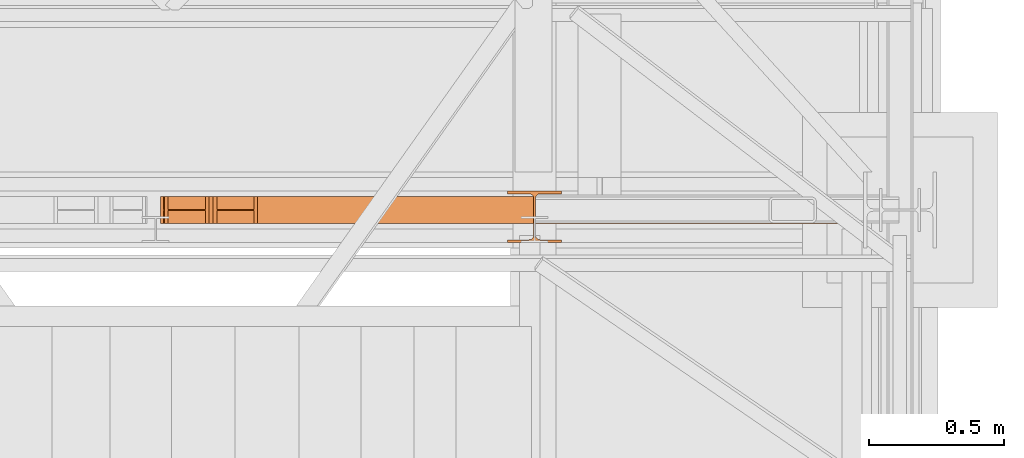
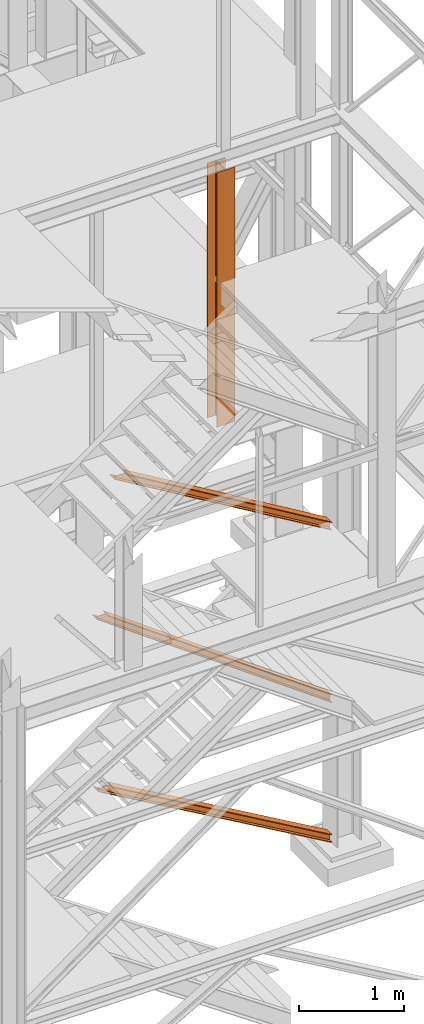
# One storey, part 56 of 208: 4 proxies.
"""IFC2X3 building model written with IfcOpenShell, lengths in millimetres."""

from ifc_helpers import new_model, entity, si_unit, converted_unit, frame, origin, origin_with_axes, place, context, subcontext, project, spatial, faceted_brep, element, save


model = new_model("IFC2X3")

# Units and contexts
model_context = context("Model", 3, precision=1e-05, world=origin())
plan_context = context("Plan", 3, precision=1e-05, world=origin())
body_context = subcontext(model_context, "Body", "Model", "MODEL_VIEW")
ifc_project = project(units=[si_unit("LENGTHUNIT", "METRE", prefix="MILLI"), converted_unit("PLANEANGLEUNIT", "DEGREE", entity("IfcPlaneAngleMeasure", 0.0174532925199433), si_unit("PLANEANGLEUNIT", "RADIAN"), dimensions=[0, 0, 0, 0, 0, 0, 0]), si_unit("AREAUNIT", "SQUARE_METRE"), si_unit("VOLUMEUNIT", "CUBIC_METRE")], contexts=[model_context, plan_context])

# Building, storey
building_placement = place(None, origin())
building = spatial("IfcBuilding", under=ifc_project, at=building_placement, CompositionType="COMPLEX")
storey_placement = place(building_placement, origin_with_axes())
storey = spatial("IfcBuildingStorey", under=building, at=storey_placement, Name="Geschoss", CompositionType="ELEMENT")

# Proxies
proxy_1_placement = place(storey_placement, frame((3966.37953388816, -22112.57439031789, 1566.490000221248), z_axis=(0.0, 0.0, 1.0), x_axis=(1.0, 0.0, 0.0)))
element("IfcBuildingElementProxy", 1, at=proxy_1_placement, inside=storey, context=body_context, shape_type="Brep", body=[
    faceted_brep([(2596.885429276088, 0.00999999999839929, 88.00999999999999), (2596.885429276088, 0.00999999999839929, 96.00999999999999), (2596.885429276088, 100.0099999999984, 96.00999999999999), (2596.885429276088, 100.0099999999984, 88.00999999999999), (2596.885429276088, 52.5099999999984, 88.00999999999999), (2596.885429276088, 52.5099999999984, 8.009999999999991), (2596.885429276088, 100.0099999999984, 8.009999999999991), (2596.885429276088, 100.0099999999984, 0.009999999999990905), (2596.885429276088, 0.00999999999839929, 0.009999999999990905), (2596.885429276088, 0.00999999999839929, 8.009999999999991), (2596.885429276088, 47.5099999999984, 8.009999999999991), (2596.885429276088, 47.5099999999984, 88.00999999999999), (2596.885429276088, 0.00999999999839929, 96.00999999999999), (2596.885429276088, 0.00999999999839929, 88.00999999999999), (121.5012482379625, 0.01000000000567525, 1881.009998688699), (132.5459071686873, 0.01000000000567525, 1881.009998688699), (2596.885429276088, 100.0099999999984, 96.00999999999999), (2596.885429276088, 0.00999999999839929, 96.00999999999999), (132.5459071686873, 0.01000000000567525, 1881.009998688699), (132.5459071686864, 100.0100000000057, 1881.009998688699), (2596.885429276088, 100.0099999999984, 88.00999999999999), (2596.885429276088, 100.0099999999984, 96.00999999999999), (132.5459071686864, 100.0100000000057, 1881.009998688699), (121.5012482379625, 100.010000000002, 1881.009998688699), (2596.885429276088, 52.5099999999984, 88.00999999999999), (2596.885429276088, 100.0099999999984, 88.00999999999999), (121.5012482379625, 100.010000000002, 1881.009998688699), (121.5012482379625, 52.51000000000568, 1881.009998688699), (2596.885429276088, 52.5099999999984, 8.009999999999991), (2596.885429276088, 52.5099999999984, 88.00999999999999), (121.5012482379625, 52.51000000000568, 1881.009998688699), (11.05465893072415, 52.51000000000568, 1881.009998688699), (2596.885429276088, 100.0099999999984, 8.009999999999991), (2596.885429276088, 52.5099999999984, 8.009999999999991), (11.05465893072415, 52.51000000000568, 1881.009998688699), (11.05465893072415, 100.0100000000057, 1881.009998688699), (2596.885429276088, 100.0099999999984, 0.009999999999990905), (2596.885429276088, 100.0099999999984, 8.009999999999991), (11.05465893072415, 100.0100000000057, 1881.009998688699), (0.01000000000021828, 100.0100000000057, 1881.009998688699), (2596.885429276088, 0.00999999999839929, 0.009999999999990905), (2596.885429276088, 100.0099999999984, 0.009999999999990905), (0.01000000000021828, 100.0100000000057, 1881.009998688699), (0.01000000000021828, 0.01000000000567525, 1881.009998688699), (2596.885429276088, 0.00999999999839929, 8.009999999999991), (2596.885429276088, 0.00999999999839929, 0.009999999999990905), (0.01000000000021828, 0.01000000000567525, 1881.009998688699), (11.05465893072415, 0.01000000000203727, 1881.009998688699), (2596.885429276088, 47.5099999999984, 8.009999999999991), (2596.885429276088, 0.00999999999839929, 8.009999999999991), (11.05465893072415, 0.01000000000203727, 1881.009998688699), (11.05465893072324, 47.51000000000568, 1881.0099986887), (2596.885429276088, 47.5099999999984, 88.00999999999999), (2596.885429276088, 47.5099999999984, 8.009999999999991), (11.05465893072324, 47.51000000000568, 1881.0099986887), (121.5012482379625, 47.51000000000568, 1881.009998688699), (2596.885429276088, 0.00999999999839929, 88.00999999999999), (2596.885429276088, 47.5099999999984, 88.00999999999999), (121.5012482379625, 47.51000000000568, 1881.009998688699), (121.5012482379625, 0.01000000000567525, 1881.009998688699), (121.5012482379625, 0.01000000000567525, 1881.009998688699), (121.5012482379625, 47.51000000000568, 1881.009998688699), (11.05465893072324, 47.51000000000568, 1881.0099986887), (11.05465893072415, 0.01000000000203727, 1881.009998688699), (0.01000000000021828, 0.01000000000567525, 1881.009998688699), (0.01000000000021828, 100.0100000000057, 1881.009998688699), (11.05465893072415, 100.0100000000057, 1881.009998688699), (11.05465893072415, 52.51000000000568, 1881.009998688699), (121.5012482379625, 52.51000000000568, 1881.009998688699), (121.5012482379625, 100.010000000002, 1881.009998688699), (132.5459071686864, 100.0100000000057, 1881.009998688699), (132.5459071686873, 0.01000000000567525, 1881.009998688699)], [[[0, 1, 2, 3, 4, 5, 6, 7, 8, 9, 10, 11]], [[12, 13, 14, 15]], [[16, 17, 18, 19]], [[20, 21, 22, 23]], [[24, 25, 26, 27]], [[28, 29, 30, 31]], [[32, 33, 34, 35]], [[36, 37, 38, 39]], [[40, 41, 42, 43]], [[44, 45, 46, 47]], [[48, 49, 50, 51]], [[52, 53, 54, 55]], [[56, 57, 58, 59]], [[60, 61, 62, 63, 64, 65, 66, 67, 68, 69, 70, 71]]], orient=[[False], [False], [False], [False], [False], [False], [False], [False], [False], [False], [False], [False], [False], [False]]),
])
proxy_2_placement = place(storey_placement, frame((3980.145216676689, -22112.57439031789, -65.01000000000045), z_axis=(0.0, 0.0, 1.0), x_axis=(1.0, 0.0, 0.0)))
element("IfcBuildingElementProxy", 2, at=proxy_2_placement, inside=storey, context=body_context, shape_type="Brep", body=[
    faceted_brep([(2583.11974648756, 0.00999999999839929, 88.01000000000005), (2583.11974648756, 0.00999999999839929, 96.01000000000005), (2583.11974648756, 100.0099999999984, 96.01000000000005), (2583.11974648756, 100.0099999999984, 88.01000000000005), (2583.11974648756, 52.5099999999984, 88.01000000000005), (2583.11974648756, 52.5099999999984, 8.010000000000048), (2583.11974648756, 100.0099999999984, 8.010000000000048), (2583.11974648756, 100.0099999999984, 0.01000000000004775), (2583.11974648756, 0.00999999999839929, 0.01000000000004775), (2583.11974648756, 0.00999999999839929, 8.010000000000048), (2583.11974648756, 47.5099999999984, 8.010000000000048), (2583.11974648756, 47.5099999999984, 88.01000000000005), (2583.11974648756, 0.00999999999839929, 96.01000000000005), (2583.11974648756, 0.00999999999839929, 88.01000000000005), (151.704132703544, 0.01000000000567525, 1498.509998909946), (165.4945084038664, 0.01000000000567525, 1498.509998909946), (2583.11974648756, 100.0099999999984, 96.01000000000005), (2583.11974648756, 0.00999999999839929, 96.01000000000005), (165.4945084038664, 0.01000000000567525, 1498.509998909946), (165.4945084038664, 100.010000000002, 1498.509998909947), (2583.11974648756, 100.0099999999984, 88.01000000000005), (2583.11974648756, 100.0099999999984, 96.01000000000005), (165.4945084038664, 100.010000000002, 1498.509998909947), (151.704132703544, 100.0100000000057, 1498.509998909946), (2583.11974648756, 52.5099999999984, 88.01000000000005), (2583.11974648756, 100.0099999999984, 88.01000000000005), (151.704132703544, 100.0100000000057, 1498.509998909946), (151.704132703544, 52.51000000000204, 1498.509998909946), (2583.11974648756, 52.5099999999984, 8.010000000000048), (2583.11974648756, 52.5099999999984, 88.01000000000005), (151.704132703544, 52.51000000000204, 1498.509998909946), (13.80037570032346, 52.51000000000568, 1498.509998909946), (2583.11974648756, 100.0099999999984, 8.010000000000048), (2583.11974648756, 52.5099999999984, 8.010000000000048), (13.80037570032346, 52.51000000000568, 1498.509998909946), (13.80037570032346, 100.0100000000057, 1498.509998909946), (2583.11974648756, 100.0099999999984, 0.01000000000004775), (2583.11974648756, 100.0099999999984, 8.010000000000048), (13.80037570032346, 100.0100000000057, 1498.509998909946), (0.01000000000112777, 100.0100000000057, 1498.509998909946), (2583.11974648756, 0.00999999999839929, 0.01000000000004775), (2583.11974648756, 100.0099999999984, 0.01000000000004775), (0.01000000000112777, 100.0100000000057, 1498.509998909946), (0.01000000000021828, 0.01000000000567525, 1498.509998909947), (2583.11974648756, 0.00999999999839929, 8.010000000000048), (2583.11974648756, 0.00999999999839929, 0.01000000000004775), (0.01000000000021828, 0.01000000000567525, 1498.509998909947), (13.80037570032346, 0.01000000000567525, 1498.509998909946), (2583.11974648756, 47.5099999999984, 8.010000000000048), (2583.11974648756, 0.00999999999839929, 8.010000000000048), (13.80037570032346, 0.01000000000567525, 1498.509998909946), (13.80037570032346, 47.51000000000568, 1498.509998909946), (2583.11974648756, 47.5099999999984, 88.01000000000005), (2583.11974648756, 47.5099999999984, 8.010000000000048), (13.80037570032346, 47.51000000000568, 1498.509998909946), (151.704132703544, 47.51000000000568, 1498.509998909946), (2583.11974648756, 0.00999999999839929, 88.01000000000005), (2583.11974648756, 47.5099999999984, 88.01000000000005), (151.704132703544, 47.51000000000568, 1498.509998909946), (151.704132703544, 0.01000000000567525, 1498.509998909946), (151.704132703544, 0.01000000000567525, 1498.509998909946), (151.704132703544, 47.51000000000568, 1498.509998909946), (13.80037570032346, 47.51000000000568, 1498.509998909946), (13.80037570032346, 0.01000000000567525, 1498.509998909946), (0.01000000000021828, 0.01000000000567525, 1498.509998909947), (0.01000000000112777, 100.0100000000057, 1498.509998909946), (13.80037570032346, 100.0100000000057, 1498.509998909946), (13.80037570032346, 52.51000000000568, 1498.509998909946), (151.704132703544, 52.51000000000204, 1498.509998909946), (151.704132703544, 100.0100000000057, 1498.509998909946), (165.4945084038664, 100.010000000002, 1498.509998909947), (165.4945084038664, 0.01000000000567525, 1498.509998909946)], [[[0, 1, 2, 3, 4, 5, 6, 7, 8, 9, 10, 11]], [[12, 13, 14, 15]], [[16, 17, 18, 19]], [[20, 21, 22, 23]], [[24, 25, 26, 27]], [[28, 29, 30, 31]], [[32, 33, 34, 35]], [[36, 37, 38, 39]], [[40, 41, 42, 43]], [[44, 45, 46, 47]], [[48, 49, 50, 51]], [[52, 53, 54, 55]], [[56, 57, 58, 59]], [[60, 61, 62, 63, 64, 65, 66, 67, 68, 69, 70, 71]]], orient=[[False], [False], [False], [False], [False], [False], [False], [False], [False], [False], [False], [False], [False], [False]]),
])
proxy_3_placement = place(storey_placement, frame((4160.397581067873, -22112.57439031789, 3580.490000221249), z_axis=(0.0, 0.0, 1.0), x_axis=(1.0, 0.0, 0.0)))
element("IfcBuildingElementProxy", 3, at=proxy_3_placement, inside=storey, context=body_context, shape_type="Brep", body=[
    faceted_brep([(2402.867382096374, 0.01000000000203727, 88.00999999999976), (2402.867382096374, 0.01000000000203727, 96.00999999999976), (2402.867382096374, 100.010000000002, 96.00999999999976), (2402.867382096374, 100.010000000002, 88.00999999999976), (2402.867382096374, 52.51000000000204, 88.00999999999976), (2402.867382096374, 52.51000000000204, 8.009999999999764), (2402.867382096374, 100.010000000002, 8.009999999999764), (2402.867382096374, 100.010000000002, 0.009999999999763531), (2402.867382096374, 0.01000000000203727, 0.009999999999763531), (2402.867382096374, 0.01000000000203727, 8.009999999999764), (2402.867382096374, 47.51000000000204, 8.009999999999764), (2402.867382096374, 47.51000000000204, 88.00999999999976), (2402.867382096374, 0.01000000000203727, 96.00999999999976), (2402.867382096374, 0.01000000000203727, 88.00999999999976), (150.5628293699992, 0.01000000000567525, 1434.509994414331), (164.2494502218169, 0.01000000000567525, 1434.509994414331), (2402.867382096374, 100.010000000002, 96.00999999999976), (2402.867382096374, 0.01000000000203727, 96.00999999999976), (164.2494502218169, 0.01000000000567525, 1434.509994414331), (164.2494502218169, 100.0100000000057, 1434.509994414331), (2402.867382096374, 100.010000000002, 88.00999999999976), (2402.867382096374, 100.010000000002, 96.00999999999976), (164.2494502218169, 100.0100000000057, 1434.509994414331), (150.5628293699992, 100.0100000000057, 1434.509994414331), (2402.867382096374, 52.51000000000204, 88.00999999999976), (2402.867382096374, 100.010000000002, 88.00999999999976), (150.5628293699992, 100.0100000000057, 1434.509994414331), (150.5628293699992, 52.51000000000568, 1434.509994414331), (2402.867382096374, 52.51000000000204, 8.009999999999764), (2402.867382096374, 52.51000000000204, 88.00999999999976), (150.5628293699992, 52.51000000000568, 1434.509994414331), (13.69662085181881, 52.51000000000568, 1434.509994414331), (2402.867382096374, 100.010000000002, 8.009999999999764), (2402.867382096374, 52.51000000000204, 8.009999999999764), (13.69662085181881, 52.51000000000568, 1434.509994414331), (13.69662085181881, 100.0100000000057, 1434.509994414331), (2402.867382096374, 100.010000000002, 0.009999999999763531), (2402.867382096374, 100.010000000002, 8.009999999999764), (13.69662085181881, 100.0100000000057, 1434.509994414331), (0.01000000000021828, 100.0100000000057, 1434.509994414331), (2402.867382096374, 0.01000000000203727, 0.009999999999763531), (2402.867382096374, 100.010000000002, 0.009999999999763531), (0.01000000000021828, 100.0100000000057, 1434.509994414331), (0.01000000000112777, 0.01000000000567525, 1434.509994414331), (2402.867382096374, 0.01000000000203727, 8.009999999999764), (2402.867382096374, 0.01000000000203727, 0.009999999999763531), (0.01000000000112777, 0.01000000000567525, 1434.509994414331), (13.69662085181881, 0.01000000000567525, 1434.509994414331), (2402.867382096374, 47.51000000000204, 8.009999999999764), (2402.867382096374, 0.01000000000203727, 8.009999999999764), (13.69662085181881, 0.01000000000567525, 1434.509994414331), (13.69662085181881, 47.51000000000568, 1434.509994414331), (2402.867382096374, 47.51000000000204, 88.00999999999976), (2402.867382096374, 47.51000000000204, 8.009999999999764), (13.69662085181881, 47.51000000000568, 1434.509994414331), (150.5628293699992, 47.51000000000568, 1434.509994414331), (2402.867382096374, 0.01000000000203727, 88.00999999999976), (2402.867382096374, 47.51000000000204, 88.00999999999976), (150.5628293699992, 47.51000000000568, 1434.509994414331), (150.5628293699992, 0.01000000000567525, 1434.509994414331), (150.5628293699992, 0.01000000000567525, 1434.509994414331), (150.5628293699992, 47.51000000000568, 1434.509994414331), (13.69662085181881, 47.51000000000568, 1434.509994414331), (13.69662085181881, 0.01000000000567525, 1434.509994414331), (0.01000000000112777, 0.01000000000567525, 1434.509994414331), (0.01000000000021828, 100.0100000000057, 1434.509994414331), (13.69662085181881, 100.0100000000057, 1434.509994414331), (13.69662085181881, 52.51000000000568, 1434.509994414331), (150.5628293699992, 52.51000000000568, 1434.509994414331), (150.5628293699992, 100.0100000000057, 1434.509994414331), (164.2494502218169, 100.0100000000057, 1434.509994414331), (164.2494502218169, 0.01000000000567525, 1434.509994414331)], [[[0, 1, 2, 3, 4, 5, 6, 7, 8, 9, 10, 11]], [[12, 13, 14, 15]], [[16, 17, 18, 19]], [[20, 21, 22, 23]], [[24, 25, 26, 27]], [[28, 29, 30, 31]], [[32, 33, 34, 35]], [[36, 37, 38, 39]], [[40, 41, 42, 43]], [[44, 45, 46, 47]], [[48, 49, 50, 51]], [[52, 53, 54, 55]], [[56, 57, 58, 59]], [[60, 61, 62, 63, 64, 65, 66, 67, 68, 69, 70, 71]]], orient=[[False], [False], [False], [False], [False], [False], [False], [False], [False], [False], [False], [False], [False], [False]]),
])
proxy_4_placement = place(storey_placement, frame((5248.254967038549, -22182.57439508626, 5284.990005364416), z_axis=(0.0, 0.0, 1.0), x_axis=(1.0, 0.0, 0.0)))
element("IfcBuildingElementProxy", 4, at=proxy_4_placement, inside=storey, context=body_context, shape_type="Brep", body=[
    faceted_brep([(0.01000000000021828, 190.0100125169738, 2970.00999254942), (200.0100029802325, 190.0100125169738, 2970.00999254942), (200.0100029802325, 180.0100146031364, 2970.00999254942), (121.2600035762789, 180.0100071525558, 2970.00999254942), (111.9441915473344, 178.1454621052726, 2970.00999254942), (105.1245498640838, 171.3258190250381, 2970.00999254942), (103.2600015571716, 162.0100079274162, 2970.00999254942), (103.2600015571716, 28.00999713897545, 2970.00999254942), (105.1245498640838, 18.69418604135353, 2970.00999254942), (111.9441915473344, 11.87454296111901, 2970.00999254942), (121.2600035762789, 10.00999791383583, 2970.00999254942), (200.0100029802325, 10.00999791383583, 2970.00999254942), (200.0100029802325, 0.00999999999839929, 2970.00999254942), (0.01000000000021828, 0.00999999999839929, 2970.00999254942), (0.01000000000021828, 10.00999791383583, 2970.00999254942), (78.75999940395377, 10.00999791383583, 2970.00999254942), (88.07581143289826, 11.87454296111901, 2970.00999254942), (94.89545311614893, 18.69418604135353, 2970.00999254942), (96.76000142306111, 28.00999713897545, 2970.00999254942), (96.76000142306111, 162.0100079274162, 2970.00999254942), (94.89545311614893, 171.3258190250381, 2970.00999254942), (88.07581143289826, 178.1454621052726, 2970.00999254942), (78.75999940395377, 180.0100071525558, 2970.00999254942), (0.01000000000021828, 180.0100146031364, 2970.00999254942), (200.0100029802325, 190.0100125169738, 2970.00999254942), (0.01000000000021828, 190.0100125169738, 2970.00999254942), (0.01000000000021828, 190.0100125169738, 0.009999999999308784), (200.0100029802325, 190.0100125169738, 0.009999999999308784), (200.0100029802325, 180.0100146031364, 2970.00999254942), (200.0100029802325, 190.0100125169738, 2970.00999254942), (200.0100029802325, 190.0100125169738, 0.009999999999308784), (200.0100029802325, 180.0100146031364, 0.009999999999308784), (121.2600035762789, 180.0100071525558, 2970.00999254942), (200.0100029802325, 180.0100146031364, 2970.00999254942), (200.0100029802325, 180.0100146031364, 0.009999999999308784), (121.2600035762789, 180.0100071525558, 0.009999999999308784), (111.9441915473344, 178.1454621052726, 2970.00999254942), (121.2600035762789, 180.0100071525558, 2970.00999254942), (121.2600035762789, 180.0100071525558, 0.009999999999308784), (111.9441915473344, 178.1454621052726, 0.009999999999308784), (105.1245498640838, 171.3258190250381, 2970.00999254942), (111.9441915473344, 178.1454621052726, 2970.00999254942), (111.9441915473344, 178.1454621052726, 0.009999999999308784), (105.1245498640838, 171.3258190250381, 0.009999999999308784), (103.2600015571716, 162.0100079274162, 2970.00999254942), (105.1245498640838, 171.3258190250381, 2970.00999254942), (105.1245498640838, 171.3258190250381, 0.009999999999308784), (103.2600015571716, 162.0100079274162, 0.009999999999308784), (103.2600015571716, 28.00999713897545, 2970.00999254942), (103.2600015571716, 162.0100079274162, 2970.00999254942), (103.2600015571716, 162.0100079274162, 0.009999999999308784), (103.2600015571716, 28.00999713897545, 0.009999999999308784), (105.1245498640838, 18.69418604135353, 2970.00999254942), (103.2600015571716, 28.00999713897545, 2970.00999254942), (103.2600015571716, 28.00999713897545, 0.009999999999308784), (105.1245498640838, 18.69418604135353, 0.009999999999308784), (111.9441915473344, 11.87454296111901, 2970.00999254942), (105.1245498640838, 18.69418604135353, 2970.00999254942), (105.1245498640838, 18.69418604135353, 0.009999999999308784), (111.9441915473344, 11.87454296111901, 0.009999999999308784), (121.2600035762789, 10.00999791383583, 2970.00999254942), (111.9441915473344, 11.87454296111901, 2970.00999254942), (111.9441915473344, 11.87454296111901, 0.009999999999308784), (121.2600035762789, 10.00999791383583, 0.009999999999308784), (200.0100029802325, 10.00999791383583, 2970.00999254942), (121.2600035762789, 10.00999791383583, 2970.00999254942), (121.2600035762789, 10.00999791383583, 0.009999999999308784), (200.0100029802325, 10.00999791383583, 0.009999999999308784), (200.0100029802325, 0.00999999999839929, 2970.00999254942), (200.0100029802325, 10.00999791383583, 2970.00999254942), (200.0100029802325, 10.00999791383583, 0.009999999999308784), (200.0100029802325, 0.00999999999839929, 0.009999999999308784), (0.01000000000021828, 0.00999999999839929, 2970.00999254942), (200.0100029802325, 0.00999999999839929, 2970.00999254942), (200.0100029802325, 0.00999999999839929, 0.009999999999308784), (0.01000000000021828, 0.00999999999839929, 0.009999999999308784), (0.01000000000021828, 10.00999791383583, 2970.00999254942), (0.01000000000021828, 0.00999999999839929, 2970.00999254942), (0.01000000000021828, 0.00999999999839929, 0.009999999999308784), (0.01000000000021828, 10.00999791383583, 0.009999999999308784), (78.75999940395377, 10.00999791383583, 2970.00999254942), (0.01000000000021828, 10.00999791383583, 2970.00999254942), (0.01000000000021828, 10.00999791383583, 0.009999999999308784), (78.75999940395377, 10.00999791383583, 0.009999999999308784), (88.07581143289826, 11.87454296111901, 2970.00999254942), (78.75999940395377, 10.00999791383583, 2970.00999254942), (78.75999940395377, 10.00999791383583, 0.009999999999308784), (88.07581143289826, 11.87454296111901, 0.009999999999308784), (94.89545311614893, 18.69418604135353, 2970.00999254942), (88.07581143289826, 11.87454296111901, 2970.00999254942), (88.07581143289826, 11.87454296111901, 0.009999999999308784), (94.89545311614893, 18.69418604135353, 0.009999999999308784), (96.76000142306111, 28.00999713897545, 2970.00999254942), (94.89545311614893, 18.69418604135353, 2970.00999254942), (94.89545311614893, 18.69418604135353, 0.009999999999308784), (96.76000142306111, 28.00999713897545, 0.009999999999308784), (96.76000142306111, 162.0100079274162, 2970.00999254942), (96.76000142306111, 28.00999713897545, 2970.00999254942), (96.76000142306111, 28.00999713897545, 0.009999999999308784), (96.76000142306111, 162.0100079274162, 0.009999999999308784), (94.89545311614893, 171.3258190250381, 2970.00999254942), (96.76000142306111, 162.0100079274162, 2970.00999254942), (96.76000142306111, 162.0100079274162, 0.009999999999308784), (94.89545311614893, 171.3258190250381, 0.009999999999308784), (88.07581143289826, 178.1454621052726, 2970.00999254942), (94.89545311614893, 171.3258190250381, 2970.00999254942), (94.89545311614893, 171.3258190250381, 0.009999999999308784), (88.07581143289826, 178.1454621052726, 0.009999999999308784), (78.75999940395377, 180.0100071525558, 2970.00999254942), (88.07581143289826, 178.1454621052726, 2970.00999254942), (88.07581143289826, 178.1454621052726, 0.009999999999308784), (78.75999940395377, 180.0100071525558, 0.009999999999308784), (0.01000000000021828, 180.0100146031364, 2970.00999254942), (78.75999940395377, 180.0100071525558, 2970.00999254942), (78.75999940395377, 180.0100071525558, 0.009999999999308784), (0.01000000000021828, 180.0100146031364, 0.009999999999308784), (0.01000000000021828, 190.0100125169738, 2970.00999254942), (0.01000000000021828, 180.0100146031364, 2970.00999254942), (0.01000000000021828, 180.0100146031364, 0.009999999999308784), (0.01000000000021828, 190.0100125169738, 0.009999999999308784), (0.01000000000021828, 190.0100125169738, 0.009999999999308784), (0.01000000000021828, 180.0100146031364, 0.009999999999308784), (78.75999940395377, 180.0100071525558, 0.009999999999308784), (88.07581143289826, 178.1454621052726, 0.009999999999308784), (94.89545311614893, 171.3258190250381, 0.009999999999308784), (96.76000142306111, 162.0100079274162, 0.009999999999308784), (96.76000142306111, 28.00999713897545, 0.009999999999308784), (94.89545311614893, 18.69418604135353, 0.009999999999308784), (88.07581143289826, 11.87454296111901, 0.009999999999308784), (78.75999940395377, 10.00999791383583, 0.009999999999308784), (0.01000000000021828, 10.00999791383583, 0.009999999999308784), (0.01000000000021828, 0.00999999999839929, 0.009999999999308784), (200.0100029802325, 0.00999999999839929, 0.009999999999308784), (200.0100029802325, 10.00999791383583, 0.009999999999308784), (121.2600035762789, 10.00999791383583, 0.009999999999308784), (111.9441915473344, 11.87454296111901, 0.009999999999308784), (105.1245498640838, 18.69418604135353, 0.009999999999308784), (103.2600015571716, 28.00999713897545, 0.009999999999308784), (103.2600015571716, 162.0100079274162, 0.009999999999308784), (105.1245498640838, 171.3258190250381, 0.009999999999308784), (111.9441915473344, 178.1454621052726, 0.009999999999308784), (121.2600035762789, 180.0100071525558, 0.009999999999308784), (200.0100029802325, 180.0100146031364, 0.009999999999308784), (200.0100029802325, 190.0100125169738, 0.009999999999308784)], [[[0, 1, 2, 3, 4, 5, 6, 7, 8, 9, 10, 11, 12, 13, 14, 15, 16, 17, 18, 19, 20, 21, 22, 23]], [[24, 25, 26, 27]], [[28, 29, 30, 31]], [[32, 33, 34, 35]], [[36, 37, 38, 39]], [[40, 41, 42, 43]], [[44, 45, 46, 47]], [[48, 49, 50, 51]], [[52, 53, 54, 55]], [[56, 57, 58, 59]], [[60, 61, 62, 63]], [[64, 65, 66, 67]], [[68, 69, 70, 71]], [[72, 73, 74, 75]], [[76, 77, 78, 79]], [[80, 81, 82, 83]], [[84, 85, 86, 87]], [[88, 89, 90, 91]], [[92, 93, 94, 95]], [[96, 97, 98, 99]], [[100, 101, 102, 103]], [[104, 105, 106, 107]], [[108, 109, 110, 111]], [[112, 113, 114, 115]], [[116, 117, 118, 119]], [[120, 121, 122, 123, 124, 125, 126, 127, 128, 129, 130, 131, 132, 133, 134, 135, 136, 137, 138, 139, 140, 141, 142, 143]]], orient=[[False], [False], [False], [False], [False], [False], [False], [False], [False], [False], [False], [False], [False], [False], [False], [False], [False], [False], [False], [False], [False], [False], [False], [False], [False], [False]]),
])

save(model, "model.ifc")
